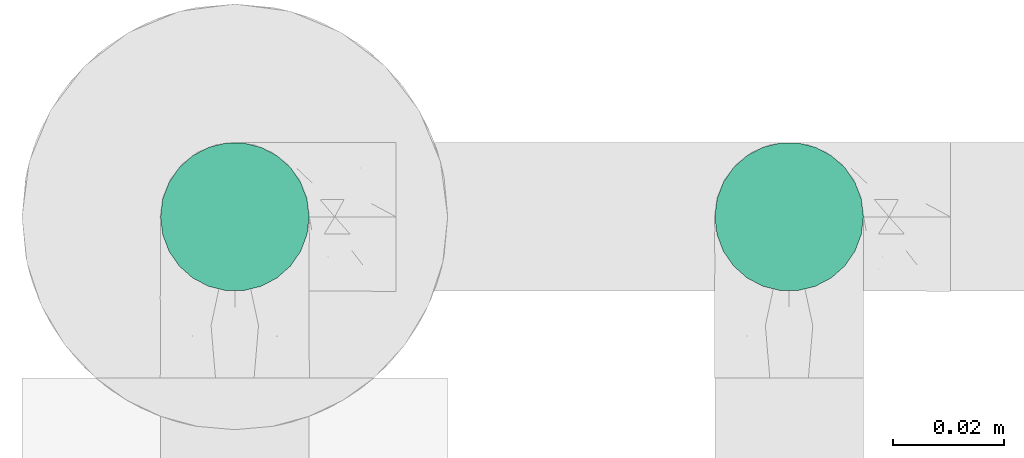
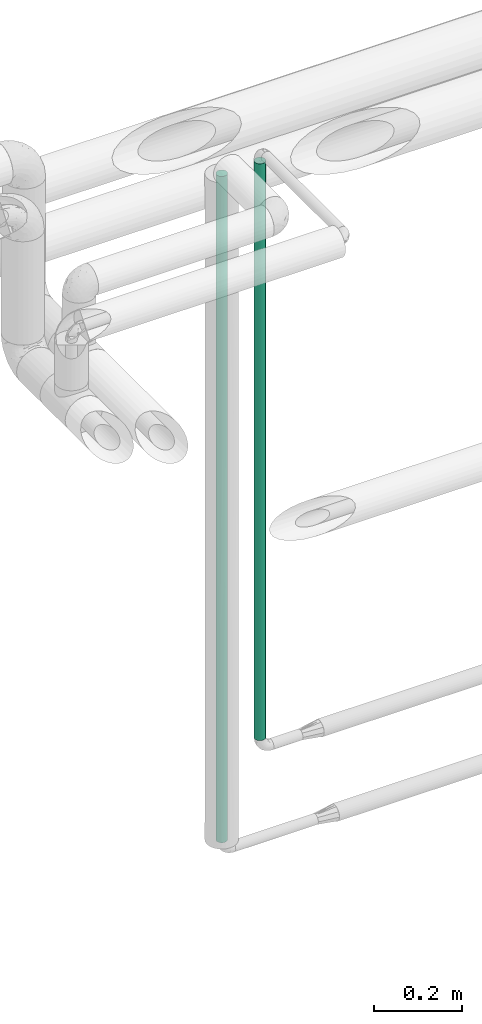
# One storey, part 538 of 827: 2 flow segments.
"""IFC2X3 building model written with IfcOpenShell, lengths in millimetres."""

from ifc_helpers import new_model, entity, si_unit, converted_unit, derived_unit, direction, frame, origin, origin_2d_with_axis, place, context, subcontext, project, spatial, circle, extrude, type_object, element, save


model = new_model("IFC2X3")

# Units and contexts
model_context = context("Model", 3, precision=0.01, world=origin(), true_north=direction((6.12303176911189e-17, 1.0)))
body_context = subcontext(model_context, "Body", "Model", "MODEL_VIEW")
ifc_project = project(units=[si_unit("LENGTHUNIT", "METRE", prefix="MILLI"), si_unit("AREAUNIT", "SQUARE_METRE"), si_unit("VOLUMEUNIT", "CUBIC_METRE"), converted_unit("PLANEANGLEUNIT", "DEGREE", entity("IfcRatioMeasure", 0.0174532925199433), si_unit("PLANEANGLEUNIT", "RADIAN"), dimensions=[0, 0, 0, 0, 0, 0, 0]), si_unit("MASSUNIT", "GRAM", prefix="KILO"), derived_unit("MASSDENSITYUNIT", [(si_unit("MASSUNIT", "GRAM", prefix="KILO"), 1), (si_unit("LENGTHUNIT", "METRE"), -3)]), derived_unit("MOMENTOFINERTIAUNIT", [(si_unit("LENGTHUNIT", "METRE"), 4)]), si_unit("TIMEUNIT", "SECOND"), si_unit("FREQUENCYUNIT", "HERTZ"), si_unit("THERMODYNAMICTEMPERATUREUNIT", "DEGREE_CELSIUS"), derived_unit("THERMALTRANSMITTANCEUNIT", [(si_unit("MASSUNIT", "GRAM", prefix="KILO"), 1), (si_unit("THERMODYNAMICTEMPERATUREUNIT", "KELVIN"), -1), (si_unit("TIMEUNIT", "SECOND"), -3)]), derived_unit("VOLUMETRICFLOWRATEUNIT", [(si_unit("LENGTHUNIT", "METRE"), 3), (si_unit("TIMEUNIT", "SECOND"), -1)]), derived_unit("MASSFLOWRATEUNIT", [(si_unit("MASSUNIT", "GRAM", prefix="KILO"), 1), (si_unit("TIMEUNIT", "SECOND"), -1)]), derived_unit("ROTATIONALFREQUENCYUNIT", [(si_unit("TIMEUNIT", "SECOND"), -1)]), si_unit("ELECTRICCURRENTUNIT", "AMPERE"), si_unit("ELECTRICVOLTAGEUNIT", "VOLT"), si_unit("POWERUNIT", "WATT"), si_unit("FORCEUNIT", "NEWTON", prefix="KILO"), si_unit("ILLUMINANCEUNIT", "LUX"), si_unit("LUMINOUSFLUXUNIT", "LUMEN"), si_unit("LUMINOUSINTENSITYUNIT", "CANDELA"), derived_unit("USERDEFINED", [(si_unit("MASSUNIT", "GRAM", prefix="KILO"), -1), (si_unit("LENGTHUNIT", "METRE"), -2), (si_unit("TIMEUNIT", "SECOND"), 3), (si_unit("LUMINOUSFLUXUNIT", "LUMEN"), 1)]), derived_unit("LINEARVELOCITYUNIT", [(si_unit("LENGTHUNIT", "METRE"), 1), (si_unit("TIMEUNIT", "SECOND"), -1)]), si_unit("PRESSUREUNIT", "PASCAL"), derived_unit("USERDEFINED", [(si_unit("LENGTHUNIT", "METRE"), -2), (si_unit("MASSUNIT", "GRAM", prefix="KILO"), 1), (si_unit("TIMEUNIT", "SECOND"), -2)]), derived_unit("LINEARFORCEUNIT", [(si_unit("MASSUNIT", "GRAM", prefix="KILO"), 1), (si_unit("LENGTHUNIT", "METRE"), 1), (si_unit("TIMEUNIT", "SECOND"), -2), (si_unit("LENGTHUNIT", "METRE"), -1)]), derived_unit("PLANARFORCEUNIT", [(si_unit("MASSUNIT", "GRAM", prefix="KILO"), 1), (si_unit("LENGTHUNIT", "METRE"), 1), (si_unit("TIMEUNIT", "SECOND"), -2), (si_unit("LENGTHUNIT", "METRE"), -2)])], contexts=[model_context])

# Site, building, storey
site_placement = place(None, origin())
site = spatial("IfcSite", under=ifc_project, at=site_placement, CompositionType="ELEMENT")
building_placement = place(site_placement, origin())
building = spatial("IfcBuilding", under=site, at=building_placement, CompositionType="ELEMENT")
storey_placement = place(building_placement, frame((0.0, 0.0, 28200.0)))
storey = spatial("IfcBuildingStorey", under=building, at=storey_placement, Name="08", CompositionType="ELEMENT", Elevation=28200.0)

# Flow segments
pipe_segment_type = type_object("IfcPipeSegmentType", PredefinedType="NOTDEFINED")
flow_segment_1_placement = place(storey_placement, frame((41978.41, 19101.22, 1329.1)))
element("IfcFlowSegment", 1, at=flow_segment_1_placement, inside=storey, type_object=pipe_segment_type, context=body_context, shape_type="SweptSolid", body=[
    extrude(circle(Radius=13.4, at=origin_2d_with_axis()), frame((15.0, 15.0, 0.0), z_axis=(0.0, 0.0, 1.0), x_axis=(-1.0, 0.0, 0.0)), (0.0, 0.0, 1.0), 1841.80476245176),
])
flow_segment_2_placement = place(storey_placement, frame((42078.41, 19101.23, 1576.6)))
element("IfcFlowSegment", 2, at=flow_segment_2_placement, inside=storey, type_object=pipe_segment_type, context=body_context, shape_type="SweptSolid", body=[
    extrude(circle(Radius=13.4, at=origin_2d_with_axis()), frame((15.0, 15.0, 0.0), z_axis=(0.0, 0.0, 1.0), x_axis=(-1.0, 0.0, 0.0)), (0.0, 0.0, 1.0), 1594.30000000001),
])

save(model, "model.ifc")
